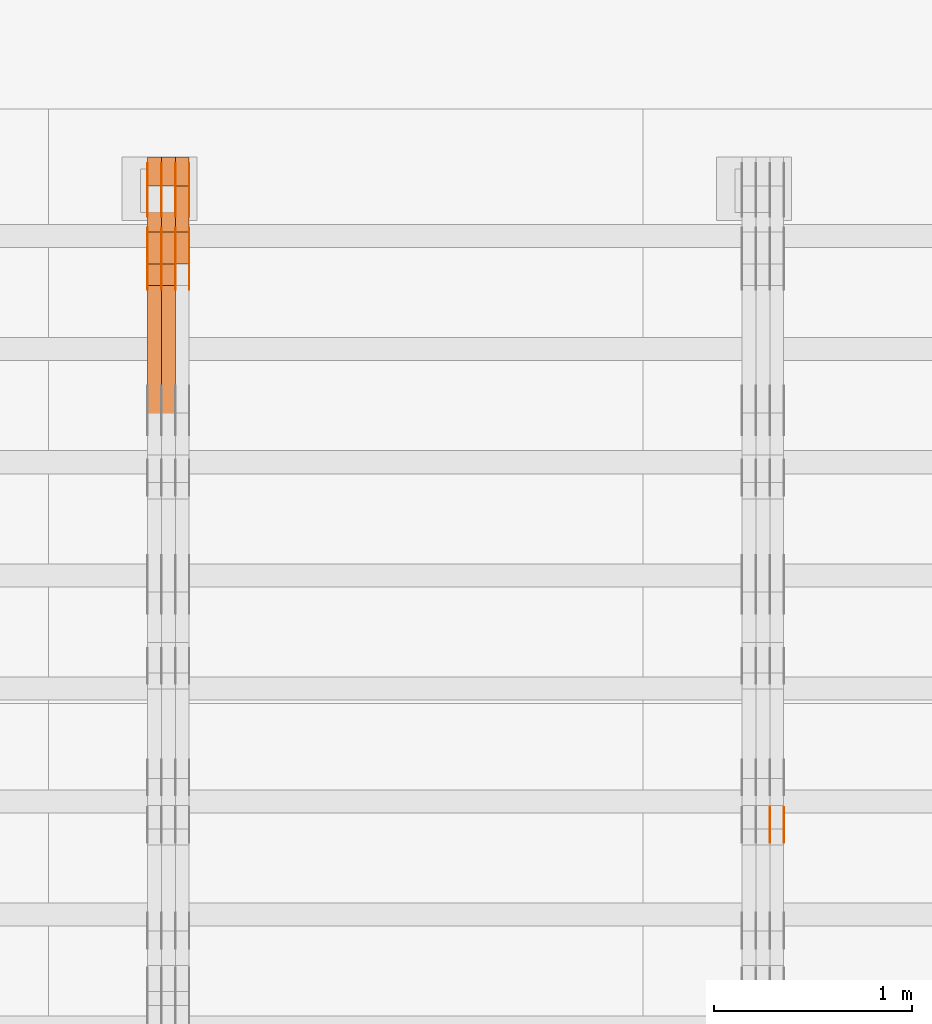
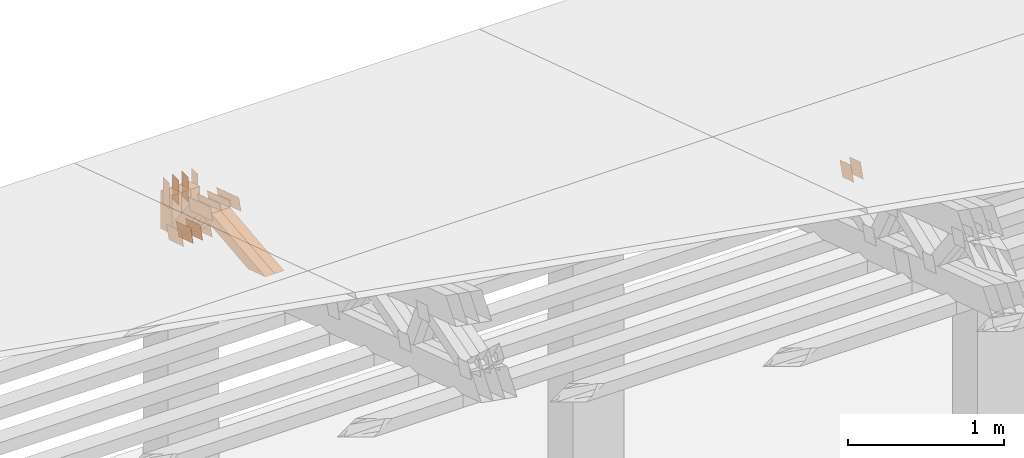
# One storey, part 344 of 385: 29 proxies.
"""IFC2X3 building model written with IfcOpenShell, lengths in millimetres."""

from ifc_helpers import new_model, entity, si_unit, converted_unit, derived_unit, direction, frame, frame_2d, origin, place, context, subcontext, project, spatial, polyline, rectangle, outline, extrude, source, transform, mapped, material, type_object, type_shapes, element, save


model = new_model("IFC2X3")

# Units and contexts
model_context = context("Model", 3, precision=0.01, world=origin(), true_north=direction((6.12303176911189e-17, 1.0)))
body_context = subcontext(model_context, "Body", "Model", "MODEL_VIEW")
ifc_project = project(units=[si_unit("LENGTHUNIT", "METRE", prefix="MILLI"), si_unit("AREAUNIT", "SQUARE_METRE"), si_unit("VOLUMEUNIT", "CUBIC_METRE"), converted_unit("PLANEANGLEUNIT", "DEGREE", entity("IfcRatioMeasure", 0.0174532925199433), si_unit("PLANEANGLEUNIT", "RADIAN"), dimensions=[0, 0, 0, 0, 0, 0, 0]), si_unit("MASSUNIT", "GRAM", prefix="KILO"), derived_unit("MASSDENSITYUNIT", [(si_unit("MASSUNIT", "GRAM", prefix="KILO"), 1), (si_unit("LENGTHUNIT", "METRE"), -3)]), si_unit("TIMEUNIT", "SECOND"), si_unit("FREQUENCYUNIT", "HERTZ"), si_unit("THERMODYNAMICTEMPERATUREUNIT", "DEGREE_CELSIUS"), derived_unit("THERMALTRANSMITTANCEUNIT", [(si_unit("MASSUNIT", "GRAM", prefix="KILO"), 1), (si_unit("THERMODYNAMICTEMPERATUREUNIT", "KELVIN"), -1), (si_unit("TIMEUNIT", "SECOND"), -3)]), derived_unit("VOLUMETRICFLOWRATEUNIT", [(si_unit("LENGTHUNIT", "METRE"), 3), (si_unit("TIMEUNIT", "SECOND"), -1)]), si_unit("ELECTRICCURRENTUNIT", "AMPERE"), si_unit("ELECTRICVOLTAGEUNIT", "VOLT"), si_unit("POWERUNIT", "WATT"), si_unit("FORCEUNIT", "NEWTON", prefix="KILO"), si_unit("ILLUMINANCEUNIT", "LUX"), si_unit("LUMINOUSFLUXUNIT", "LUMEN"), si_unit("LUMINOUSINTENSITYUNIT", "CANDELA"), derived_unit("USERDEFINED", [(si_unit("MASSUNIT", "GRAM", prefix="KILO"), -1), (si_unit("LENGTHUNIT", "METRE"), -2), (si_unit("TIMEUNIT", "SECOND"), 3), (si_unit("LUMINOUSFLUXUNIT", "LUMEN"), 1)]), derived_unit("LINEARVELOCITYUNIT", [(si_unit("LENGTHUNIT", "METRE"), 1), (si_unit("TIMEUNIT", "SECOND"), -1)]), si_unit("PRESSUREUNIT", "PASCAL"), derived_unit("USERDEFINED", [(si_unit("LENGTHUNIT", "METRE"), -2), (si_unit("MASSUNIT", "GRAM", prefix="KILO"), 1), (si_unit("TIMEUNIT", "SECOND"), -2)])], contexts=[model_context])

# Site, building, storey
site_placement = place(None, origin())
site = spatial("IfcSite", under=ifc_project, at=site_placement, CompositionType="ELEMENT")
building_placement = place(site_placement, origin())
building = spatial("IfcBuilding", under=site, at=building_placement, CompositionType="ELEMENT")
storey_placement = place(building_placement, origin())
storey = spatial("IfcBuildingStorey", under=building, at=storey_placement, Name="Default", CompositionType="ELEMENT", Elevation=0.0)

# Proxies
ifc_material_1 = material(Name="IfcSurfaceStyle #437510")
building_element_proxy_type_1 = type_object("IfcBuildingElementProxyType", PredefinedType="NOTDEFINED", material=ifc_material_1)
shared_shape_1 = source(origin(), body_context, "Body", "SweptSolid", [
    extrude(outline(polyline([(-74.9998888504569, -59.9999264677525), (74.999884859074, -59.9999264677525), (74.9998699895559, 59.9999264677525), (-74.999865998173, 59.9999264677525), (-74.9998888504569, -59.9999264677525)])), frame((74.9999170714918, 60.0000016373507, 0.0), z_axis=(0.0, 0.0, 1.0), x_axis=(-1.0, 0.0, 0.0)), (0.0, 0.0, 1.0), 1.3),
])
type_shapes(building_element_proxy_type_1, [shared_shape_1])
proxy_1_placement = place(building_placement, frame((36386.3, 23182.5962361838, 1409.76695322432), z_axis=(-1.0, 0.0, 0.0), x_axis=(0.0, -0.951056516295154, 0.309016994374948)))
element("IfcBuildingElementProxy", 1, at=proxy_1_placement, inside=storey, type_object=building_element_proxy_type_1, material=ifc_material_1, context=body_context, shape_type="MappedRepresentation", body=[
    mapped(shared_shape_1, transform((0.0, 0.0, 0.0), scale=1.0)),
])
ifc_material_2 = material(Name="IfcSurfaceStyle #437453")
building_element_proxy_type_2 = type_object("IfcBuildingElementProxyType", PredefinedType="NOTDEFINED", material=ifc_material_2)
shared_shape_2 = source(origin(), body_context, "Body", "SweptSolid", [
    extrude(outline(polyline([(-74.9998888504569, -59.9999264677525), (74.999884859074, -59.9999264677525), (74.9998699895559, 59.9999264677525), (-74.999865998173, 59.9999264677525), (-74.9998888504569, -59.9999264677525)])), frame((74.9999170714918, 60.0000016373507, 0.0), z_axis=(0.0, 0.0, 1.0), x_axis=(-1.0, 0.0, 0.0)), (0.0, 0.0, 1.0), 1.3),
])
type_shapes(building_element_proxy_type_2, [shared_shape_2])
proxy_2_placement = place(building_placement, frame((36315.0, 23182.5962361838, 1409.76695322432), z_axis=(-1.0, 0.0, 0.0), x_axis=(0.0, -0.951056516295154, 0.309016994374948)))
element("IfcBuildingElementProxy", 2, at=proxy_2_placement, inside=storey, type_object=building_element_proxy_type_2, material=ifc_material_2, context=body_context, shape_type="MappedRepresentation", body=[
    mapped(shared_shape_2, transform((0.0, 0.0, 0.0), scale=1.0)),
])
ifc_material_3 = material(Name="IfcSurfaceStyle #437396")
building_element_proxy_type_3 = type_object("IfcBuildingElementProxyType", PredefinedType="NOTDEFINED", material=ifc_material_3)
shared_shape_3 = source(origin(), body_context, "Body", "SweptSolid", [
    extrude(outline(polyline([(-74.9998888504569, -59.9999264677525), (74.999884859074, -59.9999264677525), (74.9998699895559, 59.9999264677525), (-74.999865998173, 59.9999264677525), (-74.9998888504569, -59.9999264677525)])), frame((74.9999170714918, 60.0000016373507, 0.0), z_axis=(0.0, 0.0, 1.0), x_axis=(-1.0, 0.0, 0.0)), (0.0, 0.0, 1.0), 1.3),
])
type_shapes(building_element_proxy_type_3, [shared_shape_3])
proxy_3_placement = place(building_placement, frame((36316.3, 23182.5962361838, 1409.76695322432), z_axis=(-1.0, 0.0, 0.0), x_axis=(0.0, -0.951056516295154, 0.309016994374948)))
element("IfcBuildingElementProxy", 3, at=proxy_3_placement, inside=storey, type_object=building_element_proxy_type_3, material=ifc_material_3, context=body_context, shape_type="MappedRepresentation", body=[
    mapped(shared_shape_3, transform((0.0, 0.0, 0.0), scale=1.0)),
])
ifc_material_4 = material(Name="IfcSurfaceStyle #412654")
building_element_proxy_type_4 = type_object("IfcBuildingElementProxyType", PredefinedType="NOTDEFINED", material=ifc_material_4)
shared_shape_4 = source(origin(), body_context, "Body", "SweptSolid", [
    extrude(outline(polyline([(-100.000024997547, -54.0000105875654), (100.000088940899, -54.0000105875654), (99.9999100805868, 54.0000105875654), (-99.9999740239394, 54.0000105875654), (-100.000024997547, -54.0000105875654)])), frame((100.000088940899, 54.0000474633838, 0.0), z_axis=(0.0, 0.0, 1.0), x_axis=(-1.0, 0.0, 0.0)), (0.0, 0.0, 1.0), 1.3),
])
type_shapes(building_element_proxy_type_4, [shared_shape_4])
proxy_4_placement = place(building_placement, frame((33386.3, 26390.6212638563, 73.3227520411355), z_axis=(-1.0, 0.0, 0.0), x_axis=(0.0, -0.951056516295124, 0.309016994375039)))
element("IfcBuildingElementProxy", 4, at=proxy_4_placement, inside=storey, type_object=building_element_proxy_type_4, material=ifc_material_4, context=body_context, shape_type="MappedRepresentation", body=[
    mapped(shared_shape_4, transform((0.0, 0.0, 0.0), scale=1.0)),
])
ifc_material_5 = material(Name="IfcSurfaceStyle #412597")
building_element_proxy_type_5 = type_object("IfcBuildingElementProxyType", PredefinedType="NOTDEFINED", material=ifc_material_5)
shared_shape_5 = source(origin(), body_context, "Body", "SweptSolid", [
    extrude(outline(polyline([(-100.000024997547, -54.0000105875654), (100.000088940899, -54.0000105875654), (99.9999100805868, 54.0000105875654), (-99.9999740239394, 54.0000105875654), (-100.000024997547, -54.0000105875654)])), frame((100.000088940899, 54.0000474633838, 0.0), z_axis=(0.0, 0.0, 1.0), x_axis=(-1.0, 0.0, 0.0)), (0.0, 0.0, 1.0), 1.3),
])
type_shapes(building_element_proxy_type_5, [shared_shape_5])
proxy_5_placement = place(building_placement, frame((33315.0, 26390.6212638563, 73.3227520411355), z_axis=(-1.0, 0.0, 0.0), x_axis=(0.0, -0.951056516295124, 0.309016994375039)))
element("IfcBuildingElementProxy", 5, at=proxy_5_placement, inside=storey, type_object=building_element_proxy_type_5, material=ifc_material_5, context=body_context, shape_type="MappedRepresentation", body=[
    mapped(shared_shape_5, transform((0.0, 0.0, 0.0), scale=1.0)),
])
ifc_material_6 = material(Name="IfcSurfaceStyle #412540")
building_element_proxy_type_6 = type_object("IfcBuildingElementProxyType", PredefinedType="NOTDEFINED", material=ifc_material_6)
shared_shape_6 = source(origin(), body_context, "Body", "SweptSolid", [
    extrude(outline(polyline([(-100.000024997547, -54.0000105875654), (100.000088940899, -54.0000105875654), (99.9999100805868, 54.0000105875654), (-99.9999740239394, 54.0000105875654), (-100.000024997547, -54.0000105875654)])), frame((100.000088940899, 54.0000474633838, 0.0), z_axis=(0.0, 0.0, 1.0), x_axis=(-1.0, 0.0, 0.0)), (0.0, 0.0, 1.0), 1.3),
])
type_shapes(building_element_proxy_type_6, [shared_shape_6])
proxy_6_placement = place(building_placement, frame((33316.3, 26390.6212638563, 73.3227520411355), z_axis=(-1.0, 0.0, 0.0), x_axis=(0.0, -0.951056516295124, 0.309016994375039)))
element("IfcBuildingElementProxy", 6, at=proxy_6_placement, inside=storey, type_object=building_element_proxy_type_6, material=ifc_material_6, context=body_context, shape_type="MappedRepresentation", body=[
    mapped(shared_shape_6, transform((0.0, 0.0, 0.0), scale=1.0)),
])
ifc_material_7 = material(Name="IfcSurfaceStyle #412483")
building_element_proxy_type_7 = type_object("IfcBuildingElementProxyType", PredefinedType="NOTDEFINED", material=ifc_material_7)
shared_shape_7 = source(origin(), body_context, "Body", "SweptSolid", [
    extrude(outline(polyline([(-100.000024997547, -54.0000105875654), (100.000088940899, -54.0000105875654), (99.9999100805868, 54.0000105875654), (-99.9999740239394, 54.0000105875654), (-100.000024997547, -54.0000105875654)])), frame((100.000088940899, 54.0000474633838, 0.0), z_axis=(0.0, 0.0, 1.0), x_axis=(-1.0, 0.0, 0.0)), (0.0, 0.0, 1.0), 1.29999999999998),
])
type_shapes(building_element_proxy_type_7, [shared_shape_7])
proxy_7_placement = place(building_placement, frame((33245.0, 26390.6212638563, 73.3227520411355), z_axis=(-1.0, 0.0, 0.0), x_axis=(0.0, -0.951056516295124, 0.309016994375039)))
element("IfcBuildingElementProxy", 7, at=proxy_7_placement, inside=storey, type_object=building_element_proxy_type_7, material=ifc_material_7, context=body_context, shape_type="MappedRepresentation", body=[
    mapped(shared_shape_7, transform((0.0, 0.0, 0.0), scale=1.0)),
])
ifc_material_8 = material(Name="IfcSurfaceStyle #412426")
building_element_proxy_type_8 = type_object("IfcBuildingElementProxyType", PredefinedType="NOTDEFINED", material=ifc_material_8)
shared_shape_8 = source(origin(), body_context, "Body", "SweptSolid", [
    extrude(outline(polyline([(-100.000024997547, -54.0000105875654), (100.000088940899, -54.0000105875654), (99.9999100805868, 54.0000105875654), (-99.9999740239394, 54.0000105875654), (-100.000024997547, -54.0000105875654)])), frame((100.000088940899, 54.0000474633838, 0.0), z_axis=(0.0, 0.0, 1.0), x_axis=(-1.0, 0.0, 0.0)), (0.0, 0.0, 1.0), 1.29999999999998),
])
type_shapes(building_element_proxy_type_8, [shared_shape_8])
proxy_8_placement = place(building_placement, frame((33246.3, 26390.6212638563, 73.3227520411355), z_axis=(-1.0, 0.0, 0.0), x_axis=(0.0, -0.951056516295124, 0.309016994375039)))
element("IfcBuildingElementProxy", 8, at=proxy_8_placement, inside=storey, type_object=building_element_proxy_type_8, material=ifc_material_8, context=body_context, shape_type="MappedRepresentation", body=[
    mapped(shared_shape_8, transform((0.0, 0.0, 0.0), scale=1.0)),
])
ifc_material_9 = material(Name="IfcSurfaceStyle #412369")
building_element_proxy_type_9 = type_object("IfcBuildingElementProxyType", PredefinedType="NOTDEFINED", material=ifc_material_9)
shared_shape_9 = source(origin(), body_context, "Body", "SweptSolid", [
    extrude(outline(polyline([(-100.000024997547, -54.0000105875654), (100.000088940899, -54.0000105875654), (99.9999100805868, 54.0000105875654), (-99.9999740239394, 54.0000105875654), (-100.000024997547, -54.0000105875654)])), frame((100.000088940899, 54.0000474633838, 0.0), z_axis=(0.0, 0.0, 1.0), x_axis=(-1.0, 0.0, 0.0)), (0.0, 0.0, 1.0), 1.29999999999999),
])
type_shapes(building_element_proxy_type_9, [shared_shape_9])
proxy_9_placement = place(building_placement, frame((33175.0, 26390.6212638563, 73.3227520411355), z_axis=(-1.0, 0.0, 0.0), x_axis=(0.0, -0.951056516295124, 0.309016994375039)))
element("IfcBuildingElementProxy", 9, at=proxy_9_placement, inside=storey, type_object=building_element_proxy_type_9, material=ifc_material_9, context=body_context, shape_type="MappedRepresentation", body=[
    mapped(shared_shape_9, transform((0.0, 0.0, 0.0), scale=1.0)),
])
ifc_material_10 = material(Name="IfcSurfaceStyle #400000")
building_element_proxy_type_10 = type_object("IfcBuildingElementProxyType", PredefinedType="NOTDEFINED", material=ifc_material_10)
shared_shape_10 = source(origin(), body_context, "Body", "SweptSolid", [
    extrude(outline(polyline([(-149.999901061401, -48.0000057587028), (150.000035297123, -48.0000057587028), (149.999910491851, 48.0000057587028), (-150.000044727574, 48.0000057587028), (-149.999901061401, -48.0000057587028)])), frame((150.000035297123, 48.0000632585775, 0.0), z_axis=(0.0, 0.0, 1.0), x_axis=(-1.0, 0.0, 0.0)), (0.0, 0.0, 1.0), 1.29999999999999),
])
type_shapes(building_element_proxy_type_10, [shared_shape_10])
proxy_10_placement = place(building_placement, frame((33386.3, 26115.0176968219, 469.58296924555), z_axis=(-1.0, 0.0, 0.0), x_axis=(0.0, -0.951056516295154, 0.309016994374948)))
element("IfcBuildingElementProxy", 10, at=proxy_10_placement, inside=storey, type_object=building_element_proxy_type_10, material=ifc_material_10, context=body_context, shape_type="MappedRepresentation", body=[
    mapped(shared_shape_10, transform((0.0, 0.0, 0.0), scale=1.0)),
])
ifc_material_11 = material(Name="IfcSurfaceStyle #399943")
building_element_proxy_type_11 = type_object("IfcBuildingElementProxyType", PredefinedType="NOTDEFINED", material=ifc_material_11)
shared_shape_11 = source(origin(), body_context, "Body", "SweptSolid", [
    extrude(outline(polyline([(-149.999901061401, -48.0000057587028), (150.000035297123, -48.0000057587028), (149.999910491851, 48.0000057587028), (-150.000044727574, 48.0000057587028), (-149.999901061401, -48.0000057587028)])), frame((150.000035297123, 48.0000632585775, 0.0), z_axis=(0.0, 0.0, 1.0), x_axis=(-1.0, 0.0, 0.0)), (0.0, 0.0, 1.0), 1.29999999999999),
])
type_shapes(building_element_proxy_type_11, [shared_shape_11])
proxy_11_placement = place(building_placement, frame((33315.0, 26115.0176968219, 469.58296924555), z_axis=(-1.0, 0.0, 0.0), x_axis=(0.0, -0.951056516295154, 0.309016994374948)))
element("IfcBuildingElementProxy", 11, at=proxy_11_placement, inside=storey, type_object=building_element_proxy_type_11, material=ifc_material_11, context=body_context, shape_type="MappedRepresentation", body=[
    mapped(shared_shape_11, transform((0.0, 0.0, 0.0), scale=1.0)),
])
ifc_material_12 = material(Name="IfcSurfaceStyle #399886")
building_element_proxy_type_12 = type_object("IfcBuildingElementProxyType", PredefinedType="NOTDEFINED", material=ifc_material_12)
shared_shape_12 = source(origin(), body_context, "Body", "SweptSolid", [
    extrude(outline(polyline([(-149.999901061401, -48.0000057587028), (150.000035297123, -48.0000057587028), (149.999910491851, 48.0000057587028), (-150.000044727574, 48.0000057587028), (-149.999901061401, -48.0000057587028)])), frame((150.000035297123, 48.0000632585775, 0.0), z_axis=(0.0, 0.0, 1.0), x_axis=(-1.0, 0.0, 0.0)), (0.0, 0.0, 1.0), 1.29999999999999),
])
type_shapes(building_element_proxy_type_12, [shared_shape_12])
proxy_12_placement = place(building_placement, frame((33316.3, 26115.0176968219, 469.58296924555), z_axis=(-1.0, 0.0, 0.0), x_axis=(0.0, -0.951056516295154, 0.309016994374948)))
element("IfcBuildingElementProxy", 12, at=proxy_12_placement, inside=storey, type_object=building_element_proxy_type_12, material=ifc_material_12, context=body_context, shape_type="MappedRepresentation", body=[
    mapped(shared_shape_12, transform((0.0, 0.0, 0.0), scale=1.0)),
])
ifc_material_13 = material(Name="IfcSurfaceStyle #399829")
building_element_proxy_type_13 = type_object("IfcBuildingElementProxyType", PredefinedType="NOTDEFINED", material=ifc_material_13)
shared_shape_13 = source(origin(), body_context, "Body", "SweptSolid", [
    extrude(outline(polyline([(-149.999901061401, -48.0000057587028), (150.000035297123, -48.0000057587028), (149.999910491851, 48.0000057587028), (-150.000044727574, 48.0000057587028), (-149.999901061401, -48.0000057587028)])), frame((150.000035297123, 48.0000632585775, 0.0), z_axis=(0.0, 0.0, 1.0), x_axis=(-1.0, 0.0, 0.0)), (0.0, 0.0, 1.0), 1.29999999999998),
])
type_shapes(building_element_proxy_type_13, [shared_shape_13])
proxy_13_placement = place(building_placement, frame((33245.0, 26115.0176968219, 469.58296924555), z_axis=(-1.0, 0.0, 0.0), x_axis=(0.0, -0.951056516295154, 0.309016994374948)))
element("IfcBuildingElementProxy", 13, at=proxy_13_placement, inside=storey, type_object=building_element_proxy_type_13, material=ifc_material_13, context=body_context, shape_type="MappedRepresentation", body=[
    mapped(shared_shape_13, transform((0.0, 0.0, 0.0), scale=1.0)),
])
ifc_material_14 = material(Name="IfcSurfaceStyle #399772")
building_element_proxy_type_14 = type_object("IfcBuildingElementProxyType", PredefinedType="NOTDEFINED", material=ifc_material_14)
shared_shape_14 = source(origin(), body_context, "Body", "SweptSolid", [
    extrude(outline(polyline([(-149.999901061401, -48.0000057587028), (150.000035297123, -48.0000057587028), (149.999910491851, 48.0000057587028), (-150.000044727574, 48.0000057587028), (-149.999901061401, -48.0000057587028)])), frame((150.000035297123, 48.0000632585775, 0.0), z_axis=(0.0, 0.0, 1.0), x_axis=(-1.0, 0.0, 0.0)), (0.0, 0.0, 1.0), 1.29999999999998),
])
type_shapes(building_element_proxy_type_14, [shared_shape_14])
proxy_14_placement = place(building_placement, frame((33246.3, 26115.0176968219, 469.58296924555), z_axis=(-1.0, 0.0, 0.0), x_axis=(0.0, -0.951056516295154, 0.309016994374948)))
element("IfcBuildingElementProxy", 14, at=proxy_14_placement, inside=storey, type_object=building_element_proxy_type_14, material=ifc_material_14, context=body_context, shape_type="MappedRepresentation", body=[
    mapped(shared_shape_14, transform((0.0, 0.0, 0.0), scale=1.0)),
])
ifc_material_15 = material(Name="IfcSurfaceStyle #399715")
building_element_proxy_type_15 = type_object("IfcBuildingElementProxyType", PredefinedType="NOTDEFINED", material=ifc_material_15)
shared_shape_15 = source(origin(), body_context, "Body", "SweptSolid", [
    extrude(outline(polyline([(-149.999901061401, -48.0000057587028), (150.000035297123, -48.0000057587028), (149.999910491851, 48.0000057587028), (-150.000044727574, 48.0000057587028), (-149.999901061401, -48.0000057587028)])), frame((150.000035297123, 48.0000632585775, 0.0), z_axis=(0.0, 0.0, 1.0), x_axis=(-1.0, 0.0, 0.0)), (0.0, 0.0, 1.0), 1.29999999999998),
])
type_shapes(building_element_proxy_type_15, [shared_shape_15])
proxy_15_placement = place(building_placement, frame((33175.0, 26115.0176968219, 469.58296924555), z_axis=(-1.0, 0.0, 0.0), x_axis=(0.0, -0.951056516295154, 0.309016994374948)))
element("IfcBuildingElementProxy", 15, at=proxy_15_placement, inside=storey, type_object=building_element_proxy_type_15, material=ifc_material_15, context=body_context, shape_type="MappedRepresentation", body=[
    mapped(shared_shape_15, transform((0.0, 0.0, 0.0), scale=1.0)),
])
ifc_material_16 = material(Name="IfcSurfaceStyle #399658")
building_element_proxy_type_16 = type_object("IfcBuildingElementProxyType", PredefinedType="NOTDEFINED", material=ifc_material_16)
shared_shape_16 = source(origin(), body_context, "Body", "SweptSolid", [
    extrude(rectangle(XDim=200.0, YDim=84.0000000000005, at=frame_2d((-2.1316282072803e-14, 1.06581410364015e-14), x_axis=(1.0, 0.0))), frame((100.0, 42.0, 0.0), z_axis=(0.0, 0.0, 1.0), x_axis=(-1.0, 0.0, 0.0)), (0.0, 0.0, 1.0), 1.3),
])
type_shapes(building_element_proxy_type_16, [shared_shape_16])
proxy_16_placement = place(building_placement, frame((33386.3, 26469.5000000002, 518.521545410156), z_axis=(-1.0, 0.0, 0.0), x_axis=(0.0, 0.0, -1.0)))
element("IfcBuildingElementProxy", 16, at=proxy_16_placement, inside=storey, type_object=building_element_proxy_type_16, material=ifc_material_16, context=body_context, shape_type="MappedRepresentation", body=[
    mapped(shared_shape_16, transform((0.0, 0.0, 0.0), scale=1.0)),
])
ifc_material_17 = material(Name="IfcSurfaceStyle #399601")
building_element_proxy_type_17 = type_object("IfcBuildingElementProxyType", PredefinedType="NOTDEFINED", material=ifc_material_17)
shared_shape_17 = source(origin(), body_context, "Body", "SweptSolid", [
    extrude(rectangle(XDim=200.0, YDim=84.0000000000005, at=frame_2d((-2.1316282072803e-14, 1.06581410364015e-14), x_axis=(1.0, 0.0))), frame((100.0, 42.0, 0.0), z_axis=(0.0, 0.0, 1.0), x_axis=(-1.0, 0.0, 0.0)), (0.0, 0.0, 1.0), 1.3),
])
type_shapes(building_element_proxy_type_17, [shared_shape_17])
proxy_17_placement = place(building_placement, frame((33315.0, 26469.5000000002, 518.521545410156), z_axis=(-1.0, 0.0, 0.0), x_axis=(0.0, 0.0, -1.0)))
element("IfcBuildingElementProxy", 17, at=proxy_17_placement, inside=storey, type_object=building_element_proxy_type_17, material=ifc_material_17, context=body_context, shape_type="MappedRepresentation", body=[
    mapped(shared_shape_17, transform((0.0, 0.0, 0.0), scale=1.0)),
])
ifc_material_18 = material(Name="IfcSurfaceStyle #399544")
building_element_proxy_type_18 = type_object("IfcBuildingElementProxyType", PredefinedType="NOTDEFINED", material=ifc_material_18)
shared_shape_18 = source(origin(), body_context, "Body", "SweptSolid", [
    extrude(rectangle(XDim=200.0, YDim=84.0000000000005, at=frame_2d((-2.1316282072803e-14, 1.06581410364015e-14), x_axis=(1.0, 0.0))), frame((100.0, 42.0, 0.0), z_axis=(0.0, 0.0, 1.0), x_axis=(-1.0, 0.0, 0.0)), (0.0, 0.0, 1.0), 1.3),
])
type_shapes(building_element_proxy_type_18, [shared_shape_18])
proxy_18_placement = place(building_placement, frame((33316.3, 26469.5000000002, 518.521545410156), z_axis=(-1.0, 0.0, 0.0), x_axis=(0.0, 0.0, -1.0)))
element("IfcBuildingElementProxy", 18, at=proxy_18_placement, inside=storey, type_object=building_element_proxy_type_18, material=ifc_material_18, context=body_context, shape_type="MappedRepresentation", body=[
    mapped(shared_shape_18, transform((0.0, 0.0, 0.0), scale=1.0)),
])
ifc_material_19 = material(Name="IfcSurfaceStyle #399487")
building_element_proxy_type_19 = type_object("IfcBuildingElementProxyType", PredefinedType="NOTDEFINED", material=ifc_material_19)
shared_shape_19 = source(origin(), body_context, "Body", "SweptSolid", [
    extrude(rectangle(XDim=200.0, YDim=84.0000000000005, at=frame_2d((-2.1316282072803e-14, 1.06581410364015e-14), x_axis=(1.0, 0.0))), frame((100.0, 42.0, 0.0), z_axis=(0.0, 0.0, 1.0), x_axis=(-1.0, 0.0, 0.0)), (0.0, 0.0, 1.0), 1.29999999999998),
])
type_shapes(building_element_proxy_type_19, [shared_shape_19])
proxy_19_placement = place(building_placement, frame((33245.0, 26469.5000000002, 518.521545410156), z_axis=(-1.0, 0.0, 0.0), x_axis=(0.0, 0.0, -1.0)))
element("IfcBuildingElementProxy", 19, at=proxy_19_placement, inside=storey, type_object=building_element_proxy_type_19, material=ifc_material_19, context=body_context, shape_type="MappedRepresentation", body=[
    mapped(shared_shape_19, transform((0.0, 0.0, 0.0), scale=1.0)),
])
ifc_material_20 = material(Name="IfcSurfaceStyle #399430")
building_element_proxy_type_20 = type_object("IfcBuildingElementProxyType", PredefinedType="NOTDEFINED", material=ifc_material_20)
shared_shape_20 = source(origin(), body_context, "Body", "SweptSolid", [
    extrude(rectangle(XDim=200.0, YDim=84.0000000000005, at=frame_2d((-2.1316282072803e-14, 1.06581410364015e-14), x_axis=(1.0, 0.0))), frame((100.0, 42.0, 0.0), z_axis=(0.0, 0.0, 1.0), x_axis=(-1.0, 0.0, 0.0)), (0.0, 0.0, 1.0), 1.29999999999998),
])
type_shapes(building_element_proxy_type_20, [shared_shape_20])
proxy_20_placement = place(building_placement, frame((33246.3, 26469.5000000002, 518.521545410156), z_axis=(-1.0, 0.0, 0.0), x_axis=(0.0, 0.0, -1.0)))
element("IfcBuildingElementProxy", 20, at=proxy_20_placement, inside=storey, type_object=building_element_proxy_type_20, material=ifc_material_20, context=body_context, shape_type="MappedRepresentation", body=[
    mapped(shared_shape_20, transform((0.0, 0.0, 0.0), scale=1.0)),
])
ifc_material_21 = material(Name="IfcSurfaceStyle #399373")
building_element_proxy_type_21 = type_object("IfcBuildingElementProxyType", PredefinedType="NOTDEFINED", material=ifc_material_21)
shared_shape_21 = source(origin(), body_context, "Body", "SweptSolid", [
    extrude(rectangle(XDim=200.0, YDim=84.0000000000005, at=frame_2d((-2.1316282072803e-14, 1.06581410364015e-14), x_axis=(1.0, 0.0))), frame((100.0, 42.0, 0.0), z_axis=(0.0, 0.0, 1.0), x_axis=(-1.0, 0.0, 0.0)), (0.0, 0.0, 1.0), 1.29999999999999),
])
type_shapes(building_element_proxy_type_21, [shared_shape_21])
proxy_21_placement = place(building_placement, frame((33175.0, 26469.5000000002, 518.521545410156), z_axis=(-1.0, 0.0, 0.0), x_axis=(0.0, 0.0, -1.0)))
element("IfcBuildingElementProxy", 21, at=proxy_21_placement, inside=storey, type_object=building_element_proxy_type_21, material=ifc_material_21, context=body_context, shape_type="MappedRepresentation", body=[
    mapped(shared_shape_21, transform((0.0, 0.0, 0.0), scale=1.0)),
])
ifc_material_22 = material(Name="IfcSurfaceStyle #388180")
building_element_proxy_type_22 = type_object("IfcBuildingElementProxyType", Name="T1-W4 388178", PredefinedType="NOTDEFINED", material=ifc_material_22)
shared_shape_22 = source(origin(), body_context, "Body", "SweptSolid", [
    extrude(outline(polyline([(-510.077325435179, -47.4999981284922), (188.854793418912, -47.4999981284922), (294.906688207675, 1.67015383116809e-05), (324.289382923648, 47.499989777723), (-297.973539115057, 47.4999897777231), (-510.077325435179, -47.4999981284922)])), frame((324.289382923648, 47.5000278316275, 0.0), z_axis=(0.0, 0.0, 1.0), x_axis=(-1.0, 0.0, 0.0)), (0.0, 0.0, 1.0), 70.0),
])
type_shapes(building_element_proxy_type_22, [shared_shape_22])
proxy_22_placement = place(building_placement, frame((33315.0, 25996.2241251556, 525.69905884318), z_axis=(-1.0, 0.0, 0.0), x_axis=(0.0, -0.994287125203057, -0.106738524701444)))
element("IfcBuildingElementProxy", 22, at=proxy_22_placement, inside=storey, type_object=building_element_proxy_type_22, material=ifc_material_22, Name="T1-W4", context=body_context, shape_type="MappedRepresentation", body=[
    mapped(shared_shape_22, transform((0.0, 0.0, 0.0), scale=1.0)),
])
ifc_material_23 = material(Name="IfcSurfaceStyle #388114")
building_element_proxy_type_23 = type_object("IfcBuildingElementProxyType", Name="T1-W4 388112", PredefinedType="NOTDEFINED", material=ifc_material_23)
shared_shape_23 = source(origin(), body_context, "Body", "SweptSolid", [
    extrude(outline(polyline([(-510.077325435179, -47.4999981284922), (188.854793418912, -47.4999981284922), (294.906688207675, 1.67015383116809e-05), (324.289382923648, 47.499989777723), (-297.973539115057, 47.4999897777231), (-510.077325435179, -47.4999981284922)])), frame((324.289382923648, 47.5000278316275, 0.0), z_axis=(0.0, 0.0, 1.0), x_axis=(-1.0, 0.0, 0.0)), (0.0, 0.0, 1.0), 70.0),
])
type_shapes(building_element_proxy_type_23, [shared_shape_23])
proxy_23_placement = place(building_placement, frame((33245.0, 25996.2241251556, 525.69905884318), z_axis=(-1.0, 0.0, 0.0), x_axis=(0.0, -0.994287125203057, -0.106738524701444)))
element("IfcBuildingElementProxy", 23, at=proxy_23_placement, inside=storey, type_object=building_element_proxy_type_23, material=ifc_material_23, Name="T1-W4", context=body_context, shape_type="MappedRepresentation", body=[
    mapped(shared_shape_23, transform((0.0, 0.0, 0.0), scale=1.0)),
])
ifc_material_24 = material(Name="IfcSurfaceStyle #387850")
building_element_proxy_type_24 = type_object("IfcBuildingElementProxyType", Name="T1-W21 387848", PredefinedType="NOTDEFINED", material=ifc_material_24)
shared_shape_24 = source(origin(), body_context, "Body", "SweptSolid", [
    extrude(outline(polyline([(-209.199362597501, -47.5000308982766), (168.813164734153, -47.5000308982766), (229.900717355638, -2.18385470334148e-05), (159.828709317766, 47.5000418175501), (-349.343228810055, 47.5000418175502), (-209.199362597501, -47.5000308982766)])), frame((229.900720156071, 47.5000418175501, 0.0), z_axis=(0.0, 0.0, 1.0), x_axis=(-1.0, 0.0, 0.0)), (0.0, 0.0, 1.0), 70.0),
])
type_shapes(building_element_proxy_type_24, [shared_shape_24])
proxy_24_placement = place(building_placement, frame((33385.0, 26317.5019908272, 112.518372832984), z_axis=(-1.0, 0.0, 0.0), x_axis=(0.0, -0.613839629272042, 0.789430750310097)))
element("IfcBuildingElementProxy", 24, at=proxy_24_placement, inside=storey, type_object=building_element_proxy_type_24, material=ifc_material_24, Name="T1-W21", context=body_context, shape_type="MappedRepresentation", body=[
    mapped(shared_shape_24, transform((0.0, 0.0, 0.0), scale=1.0)),
])
ifc_material_25 = material(Name="IfcSurfaceStyle #387784")
building_element_proxy_type_25 = type_object("IfcBuildingElementProxyType", Name="T1-W21 387782", PredefinedType="NOTDEFINED", material=ifc_material_25)
shared_shape_25 = source(origin(), body_context, "Body", "SweptSolid", [
    extrude(outline(polyline([(-209.199362597501, -47.5000308982766), (168.813164734153, -47.5000308982766), (229.900717355638, -2.18385470334148e-05), (159.828709317766, 47.5000418175501), (-349.343228810055, 47.5000418175502), (-209.199362597501, -47.5000308982766)])), frame((229.900720156071, 47.5000418175501, 0.0), z_axis=(0.0, 0.0, 1.0), x_axis=(-1.0, 0.0, 0.0)), (0.0, 0.0, 1.0), 70.0),
])
type_shapes(building_element_proxy_type_25, [shared_shape_25])
proxy_25_placement = place(building_placement, frame((33315.0, 26317.5019908272, 112.518372832984), z_axis=(-1.0, 0.0, 0.0), x_axis=(0.0, -0.613839629272042, 0.789430750310097)))
element("IfcBuildingElementProxy", 25, at=proxy_25_placement, inside=storey, type_object=building_element_proxy_type_25, material=ifc_material_25, Name="T1-W21", context=body_context, shape_type="MappedRepresentation", body=[
    mapped(shared_shape_25, transform((0.0, 0.0, 0.0), scale=1.0)),
])
ifc_material_26 = material(Name="IfcSurfaceStyle #387718")
building_element_proxy_type_26 = type_object("IfcBuildingElementProxyType", Name="T1-W21 387716", PredefinedType="NOTDEFINED", material=ifc_material_26)
shared_shape_26 = source(origin(), body_context, "Body", "SweptSolid", [
    extrude(outline(polyline([(-209.199362597501, -47.5000308982766), (168.813164734153, -47.5000308982766), (229.900717355638, -2.18385470334148e-05), (159.828709317766, 47.5000418175501), (-349.343228810055, 47.5000418175502), (-209.199362597501, -47.5000308982766)])), frame((229.900720156071, 47.5000418175501, 0.0), z_axis=(0.0, 0.0, 1.0), x_axis=(-1.0, 0.0, 0.0)), (0.0, 0.0, 1.0), 70.0),
])
type_shapes(building_element_proxy_type_26, [shared_shape_26])
proxy_26_placement = place(building_placement, frame((33245.0, 26317.5019908272, 112.518372832984), z_axis=(-1.0, 0.0, 0.0), x_axis=(0.0, -0.613839629272042, 0.789430750310097)))
element("IfcBuildingElementProxy", 26, at=proxy_26_placement, inside=storey, type_object=building_element_proxy_type_26, material=ifc_material_26, Name="T1-W21", context=body_context, shape_type="MappedRepresentation", body=[
    mapped(shared_shape_26, transform((0.0, 0.0, 0.0), scale=1.0)),
])
ifc_material_27 = material(Name="IfcSurfaceStyle #387283")
building_element_proxy_type_27 = type_object("IfcBuildingElementProxyType", Name="T1-E2 387281", PredefinedType="NOTDEFINED", material=ifc_material_27)
shared_shape_27 = source(origin(), body_context, "Body", "SweptSolid", [
    extrude(outline(polyline([(-126.644535064697, -72.4999999999998), (173.757884979248, -72.4999999999998), (126.644542694092, 72.4999999999998), (-173.757892608642, 72.4999999999998), (-126.644535064697, -72.4999999999998)])), frame((173.757890653796, 72.5000000000002, 0.0), z_axis=(0.0, 0.0, 1.0), x_axis=(-1.0, 0.0, 0.0)), (0.0, 0.0, 1.0), 70.0),
])
type_shapes(building_element_proxy_type_27, [shared_shape_27])
proxy_27_placement = place(building_placement, frame((33385.0, 26500.0, 442.078222227283), z_axis=(-1.0, 0.0, 0.0), x_axis=(0.0, 0.0, -1.0)))
element("IfcBuildingElementProxy", 27, at=proxy_27_placement, inside=storey, type_object=building_element_proxy_type_27, material=ifc_material_27, Name="T1-E2", context=body_context, shape_type="MappedRepresentation", body=[
    mapped(shared_shape_27, transform((0.0, 0.0, 0.0), scale=1.0)),
])
ifc_material_28 = material(Name="IfcSurfaceStyle #387226")
building_element_proxy_type_28 = type_object("IfcBuildingElementProxyType", Name="T1-E2 387224", PredefinedType="NOTDEFINED", material=ifc_material_28)
shared_shape_28 = source(origin(), body_context, "Body", "SweptSolid", [
    extrude(outline(polyline([(-126.644535064697, -72.4999999999998), (173.757884979248, -72.4999999999998), (126.644542694092, 72.4999999999998), (-173.757892608642, 72.4999999999998), (-126.644535064697, -72.4999999999998)])), frame((173.757890653796, 72.5000000000002, 0.0), z_axis=(0.0, 0.0, 1.0), x_axis=(-1.0, 0.0, 0.0)), (0.0, 0.0, 1.0), 70.0),
])
type_shapes(building_element_proxy_type_28, [shared_shape_28])
proxy_28_placement = place(building_placement, frame((33315.0, 26500.0, 442.078222227283), z_axis=(-1.0, 0.0, 0.0), x_axis=(0.0, 0.0, -1.0)))
element("IfcBuildingElementProxy", 28, at=proxy_28_placement, inside=storey, type_object=building_element_proxy_type_28, material=ifc_material_28, Name="T1-E2", context=body_context, shape_type="MappedRepresentation", body=[
    mapped(shared_shape_28, transform((0.0, 0.0, 0.0), scale=1.0)),
])
ifc_material_29 = material(Name="IfcSurfaceStyle #387169")
building_element_proxy_type_29 = type_object("IfcBuildingElementProxyType", Name="T1-E2 387167", PredefinedType="NOTDEFINED", material=ifc_material_29)
shared_shape_29 = source(origin(), body_context, "Body", "SweptSolid", [
    extrude(outline(polyline([(-126.644535064697, -72.4999999999998), (173.757884979248, -72.4999999999998), (126.644542694092, 72.4999999999998), (-173.757892608642, 72.4999999999998), (-126.644535064697, -72.4999999999998)])), frame((173.757890653796, 72.5000000000002, 0.0), z_axis=(0.0, 0.0, 1.0), x_axis=(-1.0, 0.0, 0.0)), (0.0, 0.0, 1.0), 70.0),
])
type_shapes(building_element_proxy_type_29, [shared_shape_29])
proxy_29_placement = place(building_placement, frame((33245.0, 26500.0, 442.078222227283), z_axis=(-1.0, 0.0, 0.0), x_axis=(0.0, 0.0, -1.0)))
element("IfcBuildingElementProxy", 29, at=proxy_29_placement, inside=storey, type_object=building_element_proxy_type_29, material=ifc_material_29, Name="T1-E2", context=body_context, shape_type="MappedRepresentation", body=[
    mapped(shared_shape_29, transform((0.0, 0.0, 0.0), scale=1.0)),
])

save(model, "model.ifc")
